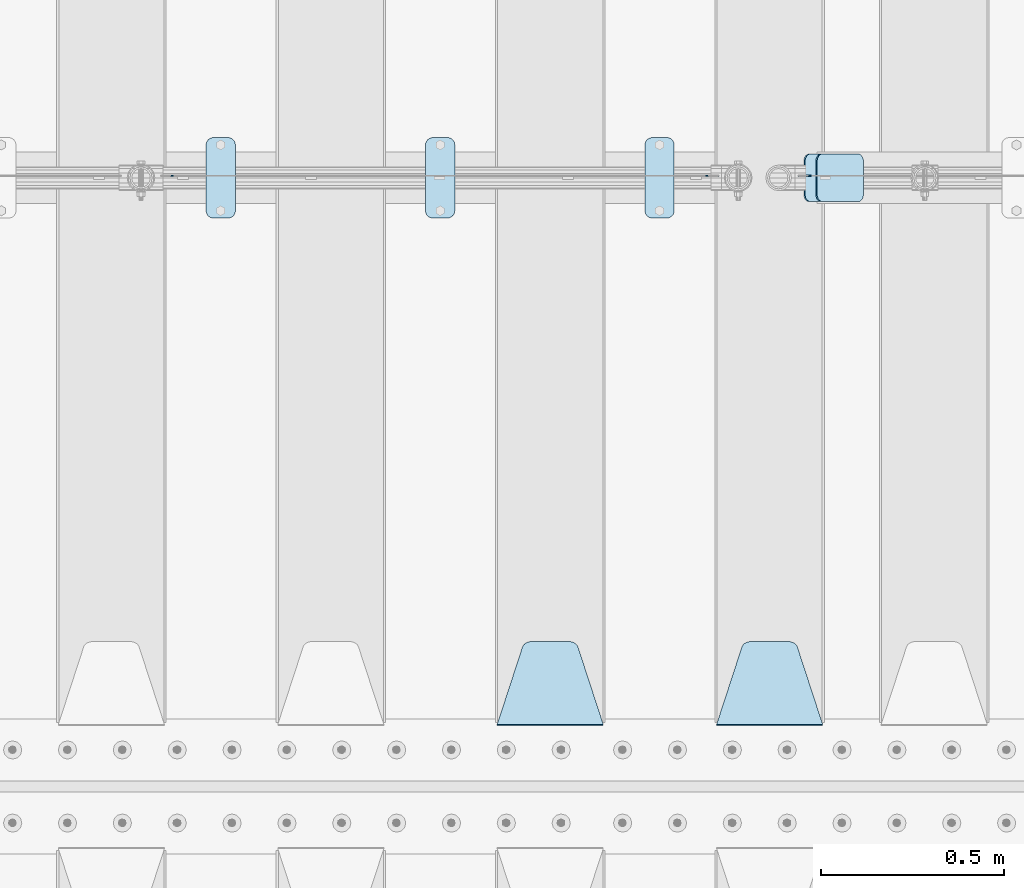
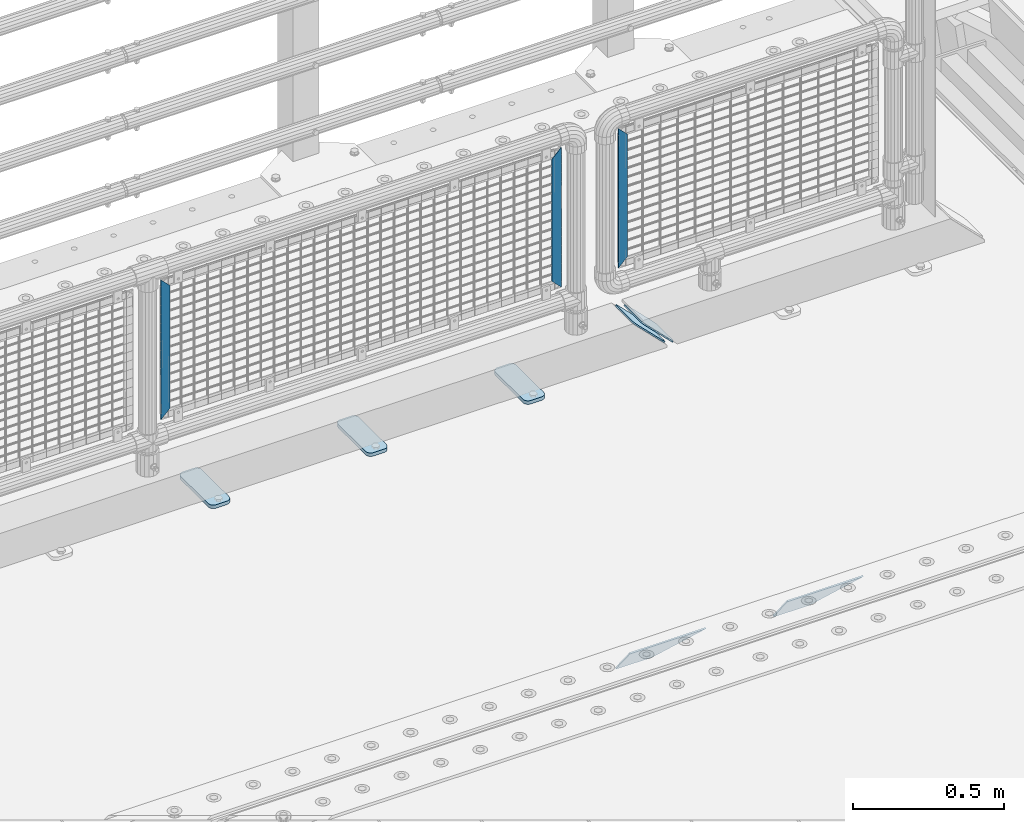
# One storey, part 223 of 242: 10 plates.
"""IFC2X3 building model written with IfcOpenShell, lengths in millimetres."""

import ifcopenshell
import ifcopenshell.guid

model = None  # the IFC model being written
_history = None  # IfcOwnerHistory: only IFC2X3 demands one
_inside = {}  # id of a spatial element -> (the spatial element, [elements in it])
_under = {}  # id of a project, library or spatial element -> (it, [spatial elements below it])
_declared = {}  # id of a project -> (the project, [libraries it declares])
_typed = {}  # id of a type object -> (the type object, [elements of that type])
_made_of = {}  # id of a material, layer set ... -> (it, [elements and type objects made of it])


def new_model(schema):
    """Start an empty IFC model of exactly this schema.

    Asked for "IFC4X3", IfcOpenShell would pick the latest addendum, in which some entities
    have other attributes; the version numbers below select the first issue.
    IFC2X3 requires an IfcOwnerHistory on every rooted entity: one is made here for all.
    """
    global model, _history
    if schema == "IFC4X3":
        model = ifcopenshell.file(schema_version=(4, 3, 0, 0))
    else:
        model = ifcopenshell.file(schema=schema)
    _inside.clear()
    _under.clear()
    _declared.clear()
    _typed.clear()
    _made_of.clear()
    _history = None
    if model.schema == "IFC2X3":
        org = make("IfcOrganization", Name="unknown")
        user = make(
            "IfcPersonAndOrganization",
            ThePerson=make("IfcPerson", FamilyName="unknown"),
            TheOrganization=org,
        )
        app = make(
            "IfcApplication",
            ApplicationDeveloper=org,
            Version="unknown",
            ApplicationFullName="unknown",
            ApplicationIdentifier="unknown",
        )
        _history = make(
            "IfcOwnerHistory",
            OwningUser=user,
            OwningApplication=app,
            ChangeAction="ADDED",
            CreationDate=0,
        )
    return model


def make(cls, **values):
    """One entity of the class cls with the attributes given. An attribute that is None is left unset."""
    return model.create_entity(
        cls, **{name: value for name, value in values.items() if value is not None}
    )


def rooted(cls, **values):
    """An entity with a GlobalId (a new one), such as an element, a storey or a relation."""
    return make(cls, GlobalId=ifcopenshell.guid.new(), OwnerHistory=_history, **values)


def si_unit(unit_type, name, prefix=None):
    """IfcSIUnit, for example si_unit("LENGTHUNIT", "METRE", prefix="MILLI")."""
    return make("IfcSIUnit", UnitType=unit_type, Prefix=prefix, Name=name)


def assignment(units):
    """IfcUnitAssignment: the units of a project."""
    return None if units is None else make("IfcUnitAssignment", Units=units)


def point(xyz):
    """IfcCartesianPoint."""
    return None if xyz is None else make("IfcCartesianPoint", Coordinates=xyz)


def direction(xyz):
    """IfcDirection."""
    return None if xyz is None else make("IfcDirection", DirectionRatios=xyz)


def frame(location, z_axis=None, x_axis=None):
    """IfcAxis2Placement3D, a coordinate frame: its origin and axes. An axis left out is left unset."""
    return make(
        "IfcAxis2Placement3D",
        Location=point(location),
        Axis=direction(z_axis),
        RefDirection=direction(x_axis),
    )


def origin_with_axes():
    """The frame at (0, 0, 0) with the z axis (0, 0, 1) and the x axis (1, 0, 0) written out."""
    return frame((0.0, 0.0, 0.0), z_axis=(0.0, 0.0, 1.0), x_axis=(1.0, 0.0, 0.0))


def place(relative_to, where):
    """IfcLocalPlacement: puts the frame where relative to a parent placement (None: the world)."""
    return make(
        "IfcLocalPlacement", PlacementRelTo=relative_to, RelativePlacement=where
    )


def context(
    kind, dimensions, precision=None, world=None, true_north=None, identifier=None
):
    """IfcGeometricRepresentationContext, for example the 3D "Model" context."""
    return make(
        "IfcGeometricRepresentationContext",
        ContextIdentifier=identifier,
        ContextType=kind,
        CoordinateSpaceDimension=dimensions,
        Precision=precision,
        WorldCoordinateSystem=world,
        TrueNorth=true_north,
    )


def subcontext(parent, identifier, kind, view, scale=None):
    """IfcGeometricRepresentationSubContext, for example "Body" below "Model"."""
    return make(
        "IfcGeometricRepresentationSubContext",
        ContextIdentifier=identifier,
        ContextType=kind,
        ParentContext=parent,
        TargetScale=scale,
        TargetView=view,
    )


def project(units=None, contexts=None):
    """IfcProject with its units and contexts."""
    return rooted(
        "IfcProject",
        Name="project",
        RepresentationContexts=contexts,
        UnitsInContext=assignment(units),
    )


def spatial(cls, under=None, at=None, **own):
    """A site, building, storey or space (cls), placed at a placement, below another one or the project."""
    s = rooted(cls, ObjectPlacement=at, **own)
    if under is not None:
        _under.setdefault(under.id(), (under, []))[1].append(s)
    return s


def faces_of(points, faces, orient=None, outer=None):
    """IfcFace entities. A face is a list of loops; a loop is a list of indices into points, from 0.

    orient and outer hold one flag for each loop. By default every Orientation is true, the
    first loop of a face is its IfcFaceOuterBound and the others are IfcFaceBound.
    """
    made = []
    for i, loops in enumerate(faces):
        bounds = []
        for j, loop in enumerate(loops):
            is_outer = j == 0 if outer is None else outer[i][j]
            bounds.append(
                make(
                    "IfcFaceOuterBound" if is_outer else "IfcFaceBound",
                    Bound=make("IfcPolyLoop", Polygon=[points[k] for k in loop]),
                    Orientation=True if orient is None else orient[i][j],
                )
            )
        made.append(make("IfcFace", Bounds=bounds))
    return made


def faceted_brep(points, faces, orient=None, outer=None, voids=None):
    """IfcFacetedBrep: a solid bounded by flat faces; with voids (closed shells), ...WithVoids."""
    shared = [point(p) for p in points]
    hull = make("IfcClosedShell", CfsFaces=faces_of(shared, faces, orient, outer))
    if voids is None:
        return make("IfcFacetedBrep", Outer=hull)
    return make(
        "IfcFacetedBrepWithVoids",
        Outer=hull,
        Voids=[
            make(cls, CfsFaces=faces_of(shared, fs, o, b)) for cls, fs, o, b in voids
        ],
    )


def shape(context_of_items, identifier, shape_type, items):
    """IfcShapeRepresentation: the items that make up one representation, for example the "Body"."""
    return make(
        "IfcShapeRepresentation",
        ContextOfItems=context_of_items,
        RepresentationIdentifier=identifier,
        RepresentationType=shape_type,
        Items=items,
    )


def material(Name=None, Category=None):
    """IfcMaterial."""
    return make("IfcMaterial", Name=Name, Category=Category)


def made_of(thing, what):
    """Note that an element or type object is made of a material, layer set ...; save() writes the relation."""
    if what is not None:
        _made_of.setdefault(what.id(), (what, []))[1].append(thing)
    return thing


def type_object(cls, material=None, **own):
    """A type object (cls), such as IfcWallType, which elements share."""
    return made_of(rooted(cls, **own), material)


def element(
    cls,
    number,
    at=None,
    inside=None,
    cuts=None,
    type_object=None,
    material=None,
    context=None,
    identifier="Body",
    shape_type=None,
    held_by="IfcProductDefinitionShape",
    body=None,
    shapes=None,
    **own,
):
    """One element of the class cls, such as IfcWall. Its Tag is "e" and its number.

    at: its placement. inside: the storey or other place that contains it. cuts: it is an
    opening in that element (IfcRelVoidsElement). A single representation is given by context,
    identifier, shape_type and body (its items); several are given by shapes. held_by: the class
    of the entity that holds the representations. save() writes the other relations.
    """
    e = rooted(cls, Tag="e%d" % number, ObjectPlacement=at, **own)
    if body is not None:
        shapes = [shape(context, identifier, shape_type, body)]
    if shapes is not None:
        e.Representation = make(held_by, Representations=shapes)
    if inside is not None:
        _inside.setdefault(inside.id(), (inside, []))[1].append(e)
    if cuts is not None:
        rooted(
            "IfcRelVoidsElement", RelatingBuildingElement=cuts, RelatedOpeningElement=e
        )
    if type_object is not None:
        _typed.setdefault(type_object.id(), (type_object, []))[1].append(e)
    return made_of(e, material)


def aggregate(whole, parts):
    """IfcRelAggregates: a whole, such as a stair, and the parts it consists of."""
    return rooted("IfcRelAggregates", RelatingObject=whole, RelatedObjects=parts)


def save(model, path):
    """Write the relations noted so far, then the file.

    IfcRelAggregates (storeys below a building ...), IfcRelContainedInSpatialStructure (elements
    in a storey), IfcRelDefinesByType, IfcRelAssociatesMaterial and IfcRelDeclares: one each for
    every whole, place, type object, material and project.
    """
    for whole, parts in _under.values():
        aggregate(whole, parts)
    for where, things in _inside.values():
        rooted(
            "IfcRelContainedInSpatialStructure",
            RelatedElements=things,
            RelatingStructure=where,
        )
    for kind, things in _typed.values():
        rooted("IfcRelDefinesByType", RelatedObjects=things, RelatingType=kind)
    for what, things in _made_of.values():
        rooted("IfcRelAssociatesMaterial", RelatedObjects=things, RelatingMaterial=what)
    for by, libraries in _declared.values():
        rooted("IfcRelDeclares", RelatingContext=by, RelatedDefinitions=libraries)
    model.write(path)


model = new_model("IFC2X3")

# Units and contexts
model_context = context("Model", 3, precision=1e-05, world=origin_with_axes())
body_context = subcontext(model_context, "Body", "Model", "MODEL_VIEW")
ifc_project = project(units=[si_unit("LENGTHUNIT", "METRE", prefix="MILLI"), si_unit("AREAUNIT", "SQUARE_METRE"), si_unit("VOLUMEUNIT", "CUBIC_METRE"), si_unit("MASSUNIT", "GRAM", prefix="KILO"), si_unit("TIMEUNIT", "SECOND"), si_unit("PLANEANGLEUNIT", "RADIAN"), si_unit("SOLIDANGLEUNIT", "STERADIAN"), si_unit("THERMODYNAMICTEMPERATUREUNIT", "DEGREE_CELSIUS"), si_unit("LUMINOUSINTENSITYUNIT", "LUMEN")], contexts=[model_context])

# Site, building, storey
site_placement = place(None, origin_with_axes())
site = spatial("IfcSite", under=ifc_project, at=site_placement, CompositionType="ELEMENT")
building_placement = place(site_placement, origin_with_axes())
building = spatial("IfcBuilding", under=site, at=building_placement, Name="Standard", CompositionType="ELEMENT")
storey_placement = place(building_placement, origin_with_axes())
storey = spatial("IfcBuildingStorey", under=building, at=storey_placement, Name="Undefined", CompositionType="ELEMENT", Elevation=0.0)

# Plates
ifc_material_1 = material(Name="Misc_Undefined")
plate_type_1 = type_object("IfcPlateType", PredefinedType="NOTDEFINED")
plate_1_placement = place(storey_placement, frame((-23666.8899741176, -19329.5000354956, 879.520017263589), z_axis=(-0.707106781186548, 0.0, -0.707106781186548), x_axis=(-0.707106781186548, 0.0, 0.707106781186548)))
element("IfcPlate", 1, at=plate_1_placement, inside=storey, type_object=plate_type_1, material=ifc_material_1, context=body_context, shape_type="Brep", body=[
    faceted_brep([(0.0, -1.50000000000364, 0.0), (-348.603637695367, -1.50000000000364, 348.603668212891), (-348.603637695367, 1.5, 348.603668212887), (-3.63797880709171e-12, 1.49999999999636, 0.0), (-348.603637695374, -1.50000000000364, 398.101165771481), (-348.603637695378, 1.5, 398.101165771481), (49.4974975585974, -1.50000000000364, 1.63709046319127e-11), (49.4974975585938, 1.49999999999636, 1.81898940354586e-11)], [[[0, 1, 2, 3]], [[1, 4, 5, 2]], [[4, 6, 7, 5]], [[6, 0, 3, 7]], [[5, 7, 3, 2]], [[6, 4, 1, 0]]]),
])
plate_2_placement = place(storey_placement, frame((-25410.490286459, -19329.5, 879.519963133601), z_axis=(-0.707008801899319, 0.0, -0.707204746899291), x_axis=(-0.707204746899296, 0.0, 0.707008801899313)))
element("IfcPlate", 2, at=plate_2_placement, inside=storey, type_object=plate_type_1, material=ifc_material_1, context=body_context, shape_type="Brep", body=[
    faceted_brep([(0.0, -1.50000000000364, 0.0), (-348.552185058597, -1.5, 348.655029296875), (-348.552185058597, 1.5, 348.655029296875), (-3.63797880709171e-12, 1.49999999999636, 0.0), (-348.544891357426, -1.5, 398.152496337891), (-348.544891357426, 1.5, 398.152496337891), (49.5043945312464, -1.5, 8.00355337560177e-11), (49.5043945312464, 1.5, 8.00355337560177e-11)], [[[0, 1, 2, 3]], [[1, 4, 5, 2]], [[4, 6, 7, 5]], [[6, 0, 3, 7]], [[5, 7, 3, 2]], [[6, 4, 1, 0]]]),
])
plate_3_placement = place(storey_placement, frame((-23954.5003125164, -19329.5, 879.52), z_axis=(0.707103624179499, 0.0, -0.707109938179501), x_axis=(0.707109938179508, 0.0, 0.707103624179492)))
element("IfcPlate", 3, at=plate_3_placement, inside=storey, type_object=plate_type_1, material=ifc_material_1, context=body_context, shape_type="Brep", body=[
    faceted_brep([(0.0, -1.50000000000364, 0.0), (-348.605163574222, -1.5, 348.602081298832), (-348.605163574222, 1.5, 348.602081298832), (-3.63797880709171e-12, 1.49999999999636, 0.0), (-348.605163574222, -1.5, 398.099334716801), (-348.605163574222, 1.5, 398.099334716801), (49.4976959228534, -1.5, -3.63797880709171e-12), (49.4976959228534, 1.5, -3.63797880709171e-12)], [[[0, 1, 2, 3]], [[1, 4, 5, 2]], [[4, 6, 7, 5]], [[6, 0, 3, 7]], [[5, 7, 3, 2]], [[6, 4, 1, 0]]]),
])
ifc_material_2 = material(Name="STEEL/S355J2")
plate_type_2 = type_object("IfcPlateType", PredefinedType="NOTDEFINED")
plate_4_placement = place(storey_placement, frame((-24121.0, -19225.5, 21.0199999999977), z_axis=(1.0, 0.0, 0.0), x_axis=(0.0, -1.0, 0.0)))
element("IfcPlate", 4, at=plate_4_placement, inside=storey, type_object=plate_type_2, material=ifc_material_2, context=body_context, shape_type="Brep", body=[
    faceted_brep([(0.0, -7.0, 20.0), (0.0, -7.0, 60.0), (0.0, 7.0, 60.0), (0.0, 7.0, 20.0), (0.384294391937146, -7.0, 63.9018064403208), (0.384294391937146, 7.0, 63.9018064403208), (1.52240934977453, -7.0, 67.6536686473009), (1.52240934977453, 7.0, 67.6536686473009), (3.37060775395003, -7.0, 71.1114046603907), (3.37060775395003, 7.0, 71.1114046603907), (5.8578643762703, -7.0, 74.1421356237297), (5.8578643762703, 7.0, 74.1421356237297), (8.88859533960931, -7.0, 76.62939224605), (8.88859533960931, 7.0, 76.62939224605), (12.3463313526991, -7.0, 78.4775906502255), (12.3463313526991, 7.0, 78.4775906502255), (16.0981935596792, -7.0, 79.6157056080629), (16.0981935596792, 7.0, 79.6157056080629), (20.0, -7.0, 80.0), (20.0, 7.0, 80.0), (200.0, -7.0, 80.0), (200.0, 7.0, 80.0), (203.901806440321, -7.0, 79.6157056080629), (203.901806440321, 7.0, 79.6157056080629), (207.653668647301, -7.0, 78.4775906502255), (207.653668647301, 7.0, 78.4775906502255), (211.111404660391, -7.0, 76.62939224605), (211.111404660391, 7.0, 76.62939224605), (214.14213562373, -7.0, 74.1421356237297), (214.14213562373, 7.0, 74.1421356237297), (216.62939224605, -7.0, 71.1114046603907), (216.62939224605, 7.0, 71.1114046603907), (218.477590650225, -7.0, 67.6536686473009), (218.477590650225, 7.0, 67.6536686473009), (219.615705608063, -7.0, 63.9018064403208), (219.615705608063, 7.0, 63.9018064403208), (220.0, -7.0, 60.0), (220.0, 7.0, 60.0), (220.0, -7.0, 20.0), (220.0, 7.0, 20.0), (219.615705608063, -7.0, 16.0981935596792), (219.615705608063, 7.0, 16.0981935596792), (218.477590650225, -7.0, 12.3463313526991), (218.477590650225, 7.0, 12.3463313526991), (216.62939224605, -7.0, 8.88859533960931), (216.62939224605, 7.0, 8.88859533960931), (214.14213562373, -7.0, 5.8578643762703), (214.14213562373, 7.0, 5.8578643762703), (211.111404660391, -7.0, 3.37060775395003), (211.111404660391, 7.0, 3.37060775395003), (207.653668647301, -7.0, 1.52240934977453), (207.653668647301, 7.0, 1.52240934977453), (203.901806440321, -7.0, 0.384294391937146), (203.901806440321, 7.0, 0.384294391937146), (200.0, -7.0, 0.0), (200.0, 7.0, 0.0), (20.0, -7.0, 0.0), (20.0, 7.0, 0.0), (16.0981935596792, -7.0, 0.384294391937146), (16.0981935596792, 7.0, 0.384294391937146), (12.3463313526991, -7.0, 1.52240934977453), (12.3463313526991, 7.0, 1.52240934977453), (8.88859533960931, -7.0, 3.37060775395003), (8.88859533960931, 7.0, 3.37060775395003), (5.8578643762703, -7.0, 5.8578643762703), (5.8578643762703, 7.0, 5.8578643762703), (3.37060775395003, -7.0, 8.88859533960931), (3.37060775395003, 7.0, 8.88859533960931), (1.52240934977453, -7.0, 12.3463313526991), (1.52240934977453, 7.0, 12.3463313526991), (0.384294391937146, -7.0, 16.0981935596792), (0.384294391937146, 7.0, 16.0981935596792)], [[[0, 1, 2, 3]], [[1, 4, 5, 2]], [[4, 6, 7, 5]], [[6, 8, 9, 7]], [[8, 10, 11, 9]], [[10, 12, 13, 11]], [[12, 14, 15, 13]], [[14, 16, 17, 15]], [[16, 18, 19, 17]], [[18, 20, 21, 19]], [[20, 22, 23, 21]], [[22, 24, 25, 23]], [[24, 26, 27, 25]], [[26, 28, 29, 27]], [[28, 30, 31, 29]], [[30, 32, 33, 31]], [[32, 34, 35, 33]], [[34, 36, 37, 35]], [[36, 38, 39, 37]], [[38, 40, 41, 39]], [[40, 42, 43, 41]], [[42, 44, 45, 43]], [[44, 46, 47, 45]], [[46, 48, 49, 47]], [[48, 50, 51, 49]], [[50, 52, 53, 51]], [[52, 54, 55, 53]], [[54, 56, 57, 55]], [[56, 58, 59, 57]], [[58, 60, 61, 59]], [[60, 62, 63, 61]], [[62, 64, 65, 63]], [[64, 66, 67, 65]], [[66, 68, 69, 67]], [[68, 70, 71, 69]], [[70, 0, 3, 71]], [[5, 7, 9, 11, 13, 15, 17, 19, 21, 23, 25, 27, 29, 31, 33, 35, 37, 39, 41, 43, 45, 47, 49, 51, 53, 55, 57, 59, 61, 63, 65, 67, 69, 71, 3, 2]], [[70, 68, 66, 64, 62, 60, 58, 56, 54, 52, 50, 48, 46, 44, 42, 40, 38, 36, 34, 32, 30, 28, 26, 24, 22, 20, 18, 16, 14, 12, 10, 8, 6, 4, 1, 0]]]),
])
plate_5_placement = place(storey_placement, frame((-24721.0, -19225.5, 21.0199999999977), z_axis=(1.0, 0.0, 0.0), x_axis=(0.0, -1.0, 0.0)))
element("IfcPlate", 5, at=plate_5_placement, inside=storey, type_object=plate_type_2, material=ifc_material_2, context=body_context, shape_type="Brep", body=[
    faceted_brep([(0.0, -7.0, 20.0), (0.0, -7.0, 60.0), (0.0, 7.0, 60.0), (0.0, 7.0, 20.0), (0.384294391937146, -7.0, 63.9018064403208), (0.384294391937146, 7.0, 63.9018064403208), (1.52240934977453, -7.0, 67.6536686473009), (1.52240934977453, 7.0, 67.6536686473009), (3.37060775395003, -7.0, 71.1114046603907), (3.37060775395003, 7.0, 71.1114046603907), (5.8578643762703, -7.0, 74.1421356237297), (5.8578643762703, 7.0, 74.1421356237297), (8.88859533960931, -7.0, 76.62939224605), (8.88859533960931, 7.0, 76.62939224605), (12.3463313526991, -7.0, 78.4775906502255), (12.3463313526991, 7.0, 78.4775906502255), (16.0981935596792, -7.0, 79.6157056080629), (16.0981935596792, 7.0, 79.6157056080629), (20.0, -7.0, 80.0), (20.0, 7.0, 80.0), (200.0, -7.0, 80.0), (200.0, 7.0, 80.0), (203.901806440321, -7.0, 79.6157056080629), (203.901806440321, 7.0, 79.6157056080629), (207.653668647301, -7.0, 78.4775906502255), (207.653668647301, 7.0, 78.4775906502255), (211.111404660391, -7.0, 76.62939224605), (211.111404660391, 7.0, 76.62939224605), (214.14213562373, -7.0, 74.1421356237297), (214.14213562373, 7.0, 74.1421356237297), (216.62939224605, -7.0, 71.1114046603907), (216.62939224605, 7.0, 71.1114046603907), (218.477590650225, -7.0, 67.6536686473009), (218.477590650225, 7.0, 67.6536686473009), (219.615705608063, -7.0, 63.9018064403208), (219.615705608063, 7.0, 63.9018064403208), (220.0, -7.0, 60.0), (220.0, 7.0, 60.0), (220.0, -7.0, 20.0), (220.0, 7.0, 20.0), (219.615705608063, -7.0, 16.0981935596792), (219.615705608063, 7.0, 16.0981935596792), (218.477590650225, -7.0, 12.3463313526991), (218.477590650225, 7.0, 12.3463313526991), (216.62939224605, -7.0, 8.88859533960931), (216.62939224605, 7.0, 8.88859533960931), (214.14213562373, -7.0, 5.8578643762703), (214.14213562373, 7.0, 5.8578643762703), (211.111404660391, -7.0, 3.37060775395003), (211.111404660391, 7.0, 3.37060775395003), (207.653668647301, -7.0, 1.52240934977453), (207.653668647301, 7.0, 1.52240934977453), (203.901806440321, -7.0, 0.384294391937146), (203.901806440321, 7.0, 0.384294391937146), (200.0, -7.0, 0.0), (200.0, 7.0, 0.0), (20.0, -7.0, 0.0), (20.0, 7.0, 0.0), (16.0981935596792, -7.0, 0.384294391937146), (16.0981935596792, 7.0, 0.384294391937146), (12.3463313526991, -7.0, 1.52240934977453), (12.3463313526991, 7.0, 1.52240934977453), (8.88859533960931, -7.0, 3.37060775395003), (8.88859533960931, 7.0, 3.37060775395003), (5.8578643762703, -7.0, 5.8578643762703), (5.8578643762703, 7.0, 5.8578643762703), (3.37060775395003, -7.0, 8.88859533960931), (3.37060775395003, 7.0, 8.88859533960931), (1.52240934977453, -7.0, 12.3463313526991), (1.52240934977453, 7.0, 12.3463313526991), (0.384294391937146, -7.0, 16.0981935596792), (0.384294391937146, 7.0, 16.0981935596792)], [[[0, 1, 2, 3]], [[1, 4, 5, 2]], [[4, 6, 7, 5]], [[6, 8, 9, 7]], [[8, 10, 11, 9]], [[10, 12, 13, 11]], [[12, 14, 15, 13]], [[14, 16, 17, 15]], [[16, 18, 19, 17]], [[18, 20, 21, 19]], [[20, 22, 23, 21]], [[22, 24, 25, 23]], [[24, 26, 27, 25]], [[26, 28, 29, 27]], [[28, 30, 31, 29]], [[30, 32, 33, 31]], [[32, 34, 35, 33]], [[34, 36, 37, 35]], [[36, 38, 39, 37]], [[38, 40, 41, 39]], [[40, 42, 43, 41]], [[42, 44, 45, 43]], [[44, 46, 47, 45]], [[46, 48, 49, 47]], [[48, 50, 51, 49]], [[50, 52, 53, 51]], [[52, 54, 55, 53]], [[54, 56, 57, 55]], [[56, 58, 59, 57]], [[58, 60, 61, 59]], [[60, 62, 63, 61]], [[62, 64, 65, 63]], [[64, 66, 67, 65]], [[66, 68, 69, 67]], [[68, 70, 71, 69]], [[70, 0, 3, 71]], [[5, 7, 9, 11, 13, 15, 17, 19, 21, 23, 25, 27, 29, 31, 33, 35, 37, 39, 41, 43, 45, 47, 49, 51, 53, 55, 57, 59, 61, 63, 65, 67, 69, 71, 3, 2]], [[70, 68, 66, 64, 62, 60, 58, 56, 54, 52, 50, 48, 46, 44, 42, 40, 38, 36, 34, 32, 30, 28, 26, 24, 22, 20, 18, 16, 14, 12, 10, 8, 6, 4, 1, 0]]]),
])
plate_6_placement = place(storey_placement, frame((-25321.0, -19225.5, 21.0199999999977), z_axis=(1.0, 0.0, 0.0), x_axis=(0.0, -1.0, 0.0)))
element("IfcPlate", 6, at=plate_6_placement, inside=storey, type_object=plate_type_2, material=ifc_material_2, context=body_context, shape_type="Brep", body=[
    faceted_brep([(0.0, -7.0, 20.0), (0.0, -7.0, 60.0), (0.0, 7.0, 60.0), (0.0, 7.0, 20.0), (0.384294391937146, -7.0, 63.9018064403208), (0.384294391937146, 7.0, 63.9018064403208), (1.52240934977453, -7.0, 67.6536686473009), (1.52240934977453, 7.0, 67.6536686473009), (3.37060775395003, -7.0, 71.1114046603907), (3.37060775395003, 7.0, 71.1114046603907), (5.8578643762703, -7.0, 74.1421356237297), (5.8578643762703, 7.0, 74.1421356237297), (8.88859533960931, -7.0, 76.62939224605), (8.88859533960931, 7.0, 76.62939224605), (12.3463313526991, -7.0, 78.4775906502255), (12.3463313526991, 7.0, 78.4775906502255), (16.0981935596792, -7.0, 79.6157056080629), (16.0981935596792, 7.0, 79.6157056080629), (20.0, -7.0, 80.0), (20.0, 7.0, 80.0), (200.0, -7.0, 80.0), (200.0, 7.0, 80.0), (203.901806440321, -7.0, 79.6157056080629), (203.901806440321, 7.0, 79.6157056080629), (207.653668647301, -7.0, 78.4775906502255), (207.653668647301, 7.0, 78.4775906502255), (211.111404660391, -7.0, 76.62939224605), (211.111404660391, 7.0, 76.62939224605), (214.14213562373, -7.0, 74.1421356237297), (214.14213562373, 7.0, 74.1421356237297), (216.62939224605, -7.0, 71.1114046603907), (216.62939224605, 7.0, 71.1114046603907), (218.477590650225, -7.0, 67.6536686473009), (218.477590650225, 7.0, 67.6536686473009), (219.615705608063, -7.0, 63.9018064403208), (219.615705608063, 7.0, 63.9018064403208), (220.0, -7.0, 60.0), (220.0, 7.0, 60.0), (220.0, -7.0, 20.0), (220.0, 7.0, 20.0), (219.615705608063, -7.0, 16.0981935596792), (219.615705608063, 7.0, 16.0981935596792), (218.477590650225, -7.0, 12.3463313526991), (218.477590650225, 7.0, 12.3463313526991), (216.62939224605, -7.0, 8.88859533960931), (216.62939224605, 7.0, 8.88859533960931), (214.14213562373, -7.0, 5.8578643762703), (214.14213562373, 7.0, 5.8578643762703), (211.111404660391, -7.0, 3.37060775395003), (211.111404660391, 7.0, 3.37060775395003), (207.653668647301, -7.0, 1.52240934977453), (207.653668647301, 7.0, 1.52240934977453), (203.901806440321, -7.0, 0.384294391937146), (203.901806440321, 7.0, 0.384294391937146), (200.0, -7.0, 0.0), (200.0, 7.0, 0.0), (20.0, -7.0, 0.0), (20.0, 7.0, 0.0), (16.0981935596792, -7.0, 0.384294391937146), (16.0981935596792, 7.0, 0.384294391937146), (12.3463313526991, -7.0, 1.52240934977453), (12.3463313526991, 7.0, 1.52240934977453), (8.88859533960931, -7.0, 3.37060775395003), (8.88859533960931, 7.0, 3.37060775395003), (5.8578643762703, -7.0, 5.8578643762703), (5.8578643762703, 7.0, 5.8578643762703), (3.37060775395003, -7.0, 8.88859533960931), (3.37060775395003, 7.0, 8.88859533960931), (1.52240934977453, -7.0, 12.3463313526991), (1.52240934977453, 7.0, 12.3463313526991), (0.384294391937146, -7.0, 16.0981935596792), (0.384294391937146, 7.0, 16.0981935596792)], [[[0, 1, 2, 3]], [[1, 4, 5, 2]], [[4, 6, 7, 5]], [[6, 8, 9, 7]], [[8, 10, 11, 9]], [[10, 12, 13, 11]], [[12, 14, 15, 13]], [[14, 16, 17, 15]], [[16, 18, 19, 17]], [[18, 20, 21, 19]], [[20, 22, 23, 21]], [[22, 24, 25, 23]], [[24, 26, 27, 25]], [[26, 28, 29, 27]], [[28, 30, 31, 29]], [[30, 32, 33, 31]], [[32, 34, 35, 33]], [[34, 36, 37, 35]], [[36, 38, 39, 37]], [[38, 40, 41, 39]], [[40, 42, 43, 41]], [[42, 44, 45, 43]], [[44, 46, 47, 45]], [[46, 48, 49, 47]], [[48, 50, 51, 49]], [[50, 52, 53, 51]], [[52, 54, 55, 53]], [[54, 56, 57, 55]], [[56, 58, 59, 57]], [[58, 60, 61, 59]], [[60, 62, 63, 61]], [[62, 64, 65, 63]], [[64, 66, 67, 65]], [[66, 68, 69, 67]], [[68, 70, 71, 69]], [[70, 0, 3, 71]], [[5, 7, 9, 11, 13, 15, 17, 19, 21, 23, 25, 27, 29, 31, 33, 35, 37, 39, 41, 43, 45, 47, 49, 51, 53, 55, 57, 59, 61, 63, 65, 67, 69, 71, 3, 2]], [[70, 68, 66, 64, 62, 60, 58, 56, 54, 52, 50, 48, 46, 44, 42, 40, 38, 36, 34, 32, 30, 28, 26, 24, 22, 20, 18, 16, 14, 12, 10, 8, 6, 4, 1, 0]]]),
])
plate_type_3 = type_object("IfcPlateType", PredefinedType="NOTDEFINED")
plate_7_placement = place(storey_placement, frame((-23684.807581521, -19270.5, 166.254400376567), z_axis=(0.707410512925777, 0.0, -0.706802918925841), x_axis=(0.0, -1.0, 0.0)))
element("IfcPlate", 7, at=plate_7_placement, inside=storey, type_object=plate_type_3, material=ifc_material_2, context=body_context, shape_type="Brep", body=[
    faceted_brep([(0.0, -2.49999999999636, 20.0), (0.0, -2.49999999999636, 158.926651000977), (0.0, 2.50000000000364, 158.926651000977), (0.0, 2.50000000000364, 20.0), (0.384294391937146, -2.49999999999636, 162.828457441301), (0.384294391937146, 2.50000000000364, 162.828457441301), (1.52240934977453, -2.49999999999636, 166.580319648281), (1.52240934977453, 2.50000000000364, 166.580319648281), (3.37060775395003, -2.49999999999636, 170.038055661371), (3.37060775395003, 2.50000000000364, 170.038055661371), (5.8578643762703, -2.49999999999636, 173.068786624706), (5.8578643762703, 2.50000000000364, 173.06878662471), (8.88859533960931, -2.5, 175.55604324703), (8.88859533960931, 2.50000000000364, 175.55604324703), (12.3463313526991, -2.49999999999636, 177.404241651206), (12.3463313526991, 2.50000000000364, 177.404241651206), (16.0981935596792, -2.49999999999636, 178.542356609043), (16.0981935596792, 2.50000000000728, 178.542356609043), (20.0, -2.49999999999272, 178.926651000977), (20.0, 2.50000000000364, 178.92665100098), (110.0, -2.49999999999272, 178.926651000977), (110.0, 2.50000000000364, 178.92665100098), (113.901806440321, -2.49999999999636, 178.542356609043), (113.901806440321, 2.50000000000728, 178.542356609043), (117.653668647301, -2.49999999999636, 177.404241651206), (117.653668647301, 2.50000000000364, 177.404241651206), (121.111404660391, -2.5, 175.55604324703), (121.111404660391, 2.50000000000364, 175.55604324703), (124.14213562373, -2.49999999999636, 173.068786624706), (124.14213562373, 2.50000000000364, 173.06878662471), (126.62939224605, -2.49999999999636, 170.038055661371), (126.62939224605, 2.50000000000364, 170.038055661371), (128.477590650225, -2.49999999999636, 166.580319648281), (128.477590650225, 2.50000000000364, 166.580319648281), (129.615705608063, -2.49999999999636, 162.828457441301), (129.615705608063, 2.50000000000364, 162.828457441301), (130.0, -2.49999999999636, 158.926651000977), (130.0, 2.50000000000364, 158.926651000977), (130.0, -2.49999999999636, 20.0), (130.0, 2.50000000000364, 20.0), (129.615705608063, -2.49999999999636, 16.0981935596792), (129.615705608063, 2.50000000000364, 16.0981935596792), (128.477590650225, -2.49999999999636, 12.3463313526991), (128.477590650225, 2.50000000000364, 12.3463313526991), (126.62939224605, -2.49999999999636, 8.88859533961295), (126.62939224605, 2.5, 8.88859533960931), (124.14213562373, -2.49999999999636, 5.8578643762703), (124.14213562373, 2.5, 5.8578643762703), (121.111404660391, -2.49999999999636, 3.37060775395003), (121.111404660391, 2.50000000000364, 3.37060775395003), (117.653668647301, -2.49999999999636, 1.52240934977453), (117.653668647301, 2.50000000000364, 1.52240934977453), (113.901806440321, -2.49999999999636, 0.384294391933508), (113.901806440321, 2.50000000000364, 0.384294391937146), (110.0, -2.49999999999636, 3.63797880709171e-12), (110.0, 2.50000000000728, 3.63797880709171e-12), (20.0, -2.49999999999636, 3.63797880709171e-12), (20.0, 2.50000000000728, 3.63797880709171e-12), (16.0981935596792, -2.49999999999636, 0.384294391933508), (16.0981935596792, 2.50000000000364, 0.384294391937146), (12.3463313526991, -2.49999999999636, 1.52240934977453), (12.3463313526991, 2.50000000000364, 1.52240934977453), (8.88859533960931, -2.49999999999636, 3.37060775395003), (8.88859533960931, 2.50000000000364, 3.37060775395003), (5.8578643762703, -2.49999999999636, 5.8578643762703), (5.8578643762703, 2.5, 5.8578643762703), (3.37060775395003, -2.49999999999636, 8.88859533961295), (3.37060775395003, 2.5, 8.88859533960931), (1.52240934977453, -2.49999999999636, 12.3463313526991), (1.52240934977453, 2.50000000000364, 12.3463313526991), (0.384294391937146, -2.49999999999636, 16.0981935596792), (0.384294391937146, 2.50000000000364, 16.0981935596792)], [[[0, 1, 2, 3]], [[1, 4, 5, 2]], [[4, 6, 7, 5]], [[6, 8, 9, 7]], [[8, 10, 11, 9]], [[10, 12, 13, 11]], [[12, 14, 15, 13]], [[14, 16, 17, 15]], [[16, 18, 19, 17]], [[18, 20, 21, 19]], [[20, 22, 23, 21]], [[22, 24, 25, 23]], [[24, 26, 27, 25]], [[26, 28, 29, 27]], [[28, 30, 31, 29]], [[30, 32, 33, 31]], [[32, 34, 35, 33]], [[34, 36, 37, 35]], [[36, 38, 39, 37]], [[38, 40, 41, 39]], [[40, 42, 43, 41]], [[42, 44, 45, 43]], [[44, 46, 47, 45]], [[46, 48, 49, 47]], [[48, 50, 51, 49]], [[50, 52, 53, 51]], [[52, 54, 55, 53]], [[54, 56, 57, 55]], [[56, 58, 59, 57]], [[58, 60, 61, 59]], [[60, 62, 63, 61]], [[62, 64, 65, 63]], [[64, 66, 67, 65]], [[66, 68, 69, 67]], [[68, 70, 71, 69]], [[70, 0, 3, 71]], [[5, 7, 9, 11, 13, 15, 17, 19, 21, 23, 25, 27, 29, 31, 33, 35, 37, 39, 41, 43, 45, 47, 49, 51, 53, 55, 57, 59, 61, 63, 65, 67, 69, 71, 3, 2]], [[70, 68, 66, 64, 62, 60, 58, 56, 54, 52, 50, 48, 46, 44, 42, 40, 38, 36, 34, 32, 30, 28, 26, 24, 22, 20, 18, 16, 14, 12, 10, 8, 6, 4, 1, 0]]]),
])
plate_8_placement = place(storey_placement, frame((-23651.8785374619, -19270.5, 156.251473717902), z_axis=(0.707410512925777, 0.0, -0.706802918925841), x_axis=(0.0, -1.0, 0.0)))
element("IfcPlate", 8, at=plate_8_placement, inside=storey, type_object=plate_type_3, material=ifc_material_2, context=body_context, shape_type="Brep", body=[
    faceted_brep([(0.0, -2.49999999999636, 20.0), (0.0, -2.49999999999636, 158.926651000977), (0.0, 2.50000000000364, 158.926651000977), (0.0, 2.50000000000364, 20.0), (0.384294391937146, -2.49999999999636, 162.828457441301), (0.384294391937146, 2.50000000000364, 162.828457441301), (1.52240934977453, -2.49999999999636, 166.580319648281), (1.52240934977453, 2.50000000000364, 166.580319648281), (3.37060775395003, -2.49999999999636, 170.038055661371), (3.37060775395003, 2.50000000000364, 170.038055661371), (5.8578643762703, -2.49999999999636, 173.068786624706), (5.8578643762703, 2.50000000000364, 173.06878662471), (8.88859533960931, -2.5, 175.55604324703), (8.88859533960931, 2.50000000000364, 175.55604324703), (12.3463313526991, -2.49999999999636, 177.404241651206), (12.3463313526991, 2.50000000000364, 177.404241651206), (16.0981935596792, -2.49999999999636, 178.542356609043), (16.0981935596792, 2.50000000000728, 178.542356609043), (20.0, -2.49999999999272, 178.926651000977), (20.0, 2.50000000000364, 178.92665100098), (110.0, -2.49999999999272, 178.926651000977), (110.0, 2.50000000000364, 178.92665100098), (113.901806440321, -2.49999999999636, 178.542356609043), (113.901806440321, 2.50000000000728, 178.542356609043), (117.653668647301, -2.49999999999636, 177.404241651206), (117.653668647301, 2.50000000000364, 177.404241651206), (121.111404660391, -2.5, 175.55604324703), (121.111404660391, 2.50000000000364, 175.55604324703), (124.14213562373, -2.49999999999636, 173.068786624706), (124.14213562373, 2.50000000000364, 173.06878662471), (126.62939224605, -2.49999999999636, 170.038055661371), (126.62939224605, 2.50000000000364, 170.038055661371), (128.477590650225, -2.49999999999636, 166.580319648281), (128.477590650225, 2.50000000000364, 166.580319648281), (129.615705608063, -2.49999999999636, 162.828457441301), (129.615705608063, 2.50000000000364, 162.828457441301), (130.0, -2.49999999999636, 158.926651000977), (130.0, 2.50000000000364, 158.926651000977), (130.0, -2.49999999999636, 20.0), (130.0, 2.50000000000364, 20.0), (129.615705608063, -2.49999999999636, 16.0981935596792), (129.615705608063, 2.50000000000364, 16.0981935596792), (128.477590650225, -2.49999999999636, 12.3463313526991), (128.477590650225, 2.50000000000364, 12.3463313526991), (126.62939224605, -2.49999999999636, 8.88859533961295), (126.62939224605, 2.5, 8.88859533960931), (124.14213562373, -2.49999999999636, 5.8578643762703), (124.14213562373, 2.5, 5.8578643762703), (121.111404660391, -2.49999999999636, 3.37060775395003), (121.111404660391, 2.50000000000364, 3.37060775395003), (117.653668647301, -2.49999999999636, 1.52240934977453), (117.653668647301, 2.50000000000364, 1.52240934977453), (113.901806440321, -2.49999999999636, 0.384294391933508), (113.901806440321, 2.50000000000364, 0.384294391937146), (110.0, -2.49999999999636, 3.63797880709171e-12), (110.0, 2.50000000000728, 3.63797880709171e-12), (20.0, -2.49999999999636, 3.63797880709171e-12), (20.0, 2.50000000000728, 3.63797880709171e-12), (16.0981935596792, -2.49999999999636, 0.384294391933508), (16.0981935596792, 2.50000000000364, 0.384294391937146), (12.3463313526991, -2.49999999999636, 1.52240934977453), (12.3463313526991, 2.50000000000364, 1.52240934977453), (8.88859533960931, -2.49999999999636, 3.37060775395003), (8.88859533960931, 2.50000000000364, 3.37060775395003), (5.8578643762703, -2.49999999999636, 5.8578643762703), (5.8578643762703, 2.5, 5.8578643762703), (3.37060775395003, -2.49999999999636, 8.88859533961295), (3.37060775395003, 2.5, 8.88859533960931), (1.52240934977453, -2.49999999999636, 12.3463313526991), (1.52240934977453, 2.50000000000364, 12.3463313526991), (0.384294391937146, -2.49999999999636, 16.0981935596792), (0.384294391937146, 2.50000000000364, 16.0981935596792)], [[[0, 1, 2, 3]], [[1, 4, 5, 2]], [[4, 6, 7, 5]], [[6, 8, 9, 7]], [[8, 10, 11, 9]], [[10, 12, 13, 11]], [[12, 14, 15, 13]], [[14, 16, 17, 15]], [[16, 18, 19, 17]], [[18, 20, 21, 19]], [[20, 22, 23, 21]], [[22, 24, 25, 23]], [[24, 26, 27, 25]], [[26, 28, 29, 27]], [[28, 30, 31, 29]], [[30, 32, 33, 31]], [[32, 34, 35, 33]], [[34, 36, 37, 35]], [[36, 38, 39, 37]], [[38, 40, 41, 39]], [[40, 42, 43, 41]], [[42, 44, 45, 43]], [[44, 46, 47, 45]], [[46, 48, 49, 47]], [[48, 50, 51, 49]], [[50, 52, 53, 51]], [[52, 54, 55, 53]], [[54, 56, 57, 55]], [[56, 58, 59, 57]], [[58, 60, 61, 59]], [[60, 62, 63, 61]], [[62, 64, 65, 63]], [[64, 66, 67, 65]], [[66, 68, 69, 67]], [[68, 70, 71, 69]], [[70, 0, 3, 71]], [[5, 7, 9, 11, 13, 15, 17, 19, 21, 23, 25, 27, 29, 31, 33, 35, 37, 39, 41, 43, 45, 47, 49, 51, 53, 55, 57, 59, 61, 63, 65, 67, 69, 71, 3, 2]], [[70, 68, 66, 64, 62, 60, 58, 56, 54, 52, 50, 48, 46, 44, 42, 40, 38, 36, 34, 32, 30, 28, 26, 24, 22, 20, 18, 16, 14, 12, 10, 8, 6, 4, 1, 0]]]),
])
ifc_material_3 = material(Name="STEEL/S355N")
plate_type_4 = type_object("IfcPlateType", PredefinedType="NOTDEFINED")
plate_9_placement = place(storey_placement, frame((-23635.0, -20831.767766953, -1.76776695296758), z_axis=(0.0, 0.707106781186547, -0.707106781186548), x_axis=(-1.0, 0.0, 0.0)))
element("IfcPlate", 9, at=plate_9_placement, inside=storey, type_object=plate_type_4, material=ifc_material_3, context=body_context, shape_type="Brep", body=[
    faceted_brep([(0.0, -2.5, 0.0), (69.345504679477, -2.50000000000182, 300.171731424829), (69.345504679477, 2.5, 300.171731424829), (0.0, 2.5, 0.0), (70.9274061199576, -2.5, 304.897442415398), (70.9274061199576, 2.5, 304.897442415398), (73.3818627772307, -2.5, 309.234538108525), (73.3818627772307, 2.50000000000182, 309.234538108529), (76.6187032999551, -2.5, 313.023683126101), (76.6187032999551, 2.50000000000182, 313.023683126103), (80.5190132704993, -2.5, 316.12567259537), (80.5190132704993, 2.5, 316.12567259537), (84.9395038596849, -2.5, 318.426546230474), (84.9395038596849, 2.50000000000182, 318.426546230476), (89.7177759439219, -2.49999999999818, 319.841774983273), (89.7177759439219, 2.50000000000182, 319.841774983273), (94.678286292652, -2.5, 320.319366455076), (94.678286292652, 2.5, 320.319366455076), (195.321713707348, -2.5, 320.319366455076), (195.321713707348, 2.5, 320.319366455076), (200.282224056078, -2.5, 319.841774983272), (200.282224056078, 2.50000000000182, 319.841774983273), (205.060496140315, -2.5, 318.426546230474), (205.060496140315, 2.49999999999818, 318.426546230474), (209.480986729501, -2.49999999999818, 316.12567259537), (209.480986729501, 2.5, 316.12567259537), (213.381296700045, -2.5, 313.023683126101), (213.381296700045, 2.49999999999818, 313.023683126101), (216.618137222769, -2.5, 309.234538108525), (216.618137222769, 2.5, 309.234538108523), (219.072593880042, -2.49999999999818, 304.897442415398), (219.072593880042, 2.50000000000182, 304.897442415398), (220.654495320523, -2.50000000000182, 300.171731424829), (220.654495320523, 2.5, 300.171731424829), (290.0, -2.5, 0.0), (290.0, 2.5, -1.81898940354586e-12)], [[[0, 1, 2, 3]], [[1, 4, 5, 2]], [[4, 6, 7, 5]], [[6, 8, 9, 7]], [[8, 10, 11, 9]], [[10, 12, 13, 11]], [[12, 14, 15, 13]], [[14, 16, 17, 15]], [[16, 18, 19, 17]], [[18, 20, 21, 19]], [[20, 22, 23, 21]], [[22, 24, 25, 23]], [[24, 26, 27, 25]], [[26, 28, 29, 27]], [[28, 30, 31, 29]], [[30, 32, 33, 31]], [[32, 34, 35, 33]], [[34, 0, 3, 35]], [[5, 7, 9, 11, 13, 15, 17, 19, 21, 23, 25, 27, 29, 31, 33, 35, 3, 2]], [[34, 32, 30, 28, 26, 24, 22, 20, 18, 16, 14, 12, 10, 8, 6, 4, 1, 0]]]),
])
plate_10_placement = place(storey_placement, frame((-24235.0, -20831.767766953, -1.76776695296758), z_axis=(0.0, 0.707106781186547, -0.707106781186548), x_axis=(-1.0, 0.0, 0.0)))
element("IfcPlate", 10, at=plate_10_placement, inside=storey, type_object=plate_type_4, material=ifc_material_3, context=body_context, shape_type="Brep", body=[
    faceted_brep([(0.0, -2.5, 0.0), (69.345504679477, -2.50000000000182, 300.171731424829), (69.345504679477, 2.5, 300.171731424829), (0.0, 2.5, 0.0), (70.9274061199576, -2.5, 304.897442415398), (70.9274061199576, 2.5, 304.897442415398), (73.3818627772307, -2.5, 309.234538108525), (73.3818627772307, 2.50000000000182, 309.234538108529), (76.6187032999551, -2.5, 313.023683126101), (76.6187032999551, 2.50000000000182, 313.023683126103), (80.5190132704993, -2.5, 316.12567259537), (80.5190132704993, 2.5, 316.12567259537), (84.9395038596849, -2.5, 318.426546230474), (84.9395038596849, 2.50000000000182, 318.426546230476), (89.7177759439219, -2.49999999999818, 319.841774983273), (89.7177759439219, 2.50000000000182, 319.841774983273), (94.678286292652, -2.5, 320.319366455076), (94.678286292652, 2.5, 320.319366455076), (195.321713707348, -2.5, 320.319366455076), (195.321713707348, 2.5, 320.319366455076), (200.282224056078, -2.5, 319.841774983272), (200.282224056078, 2.50000000000182, 319.841774983273), (205.060496140315, -2.5, 318.426546230474), (205.060496140315, 2.49999999999818, 318.426546230474), (209.480986729501, -2.49999999999818, 316.12567259537), (209.480986729501, 2.5, 316.12567259537), (213.381296700045, -2.5, 313.023683126101), (213.381296700045, 2.49999999999818, 313.023683126101), (216.618137222769, -2.5, 309.234538108525), (216.618137222769, 2.5, 309.234538108523), (219.072593880042, -2.49999999999818, 304.897442415398), (219.072593880042, 2.50000000000182, 304.897442415398), (220.654495320523, -2.50000000000182, 300.171731424829), (220.654495320523, 2.5, 300.171731424829), (290.0, -2.5, 0.0), (290.0, 2.5, -1.81898940354586e-12)], [[[0, 1, 2, 3]], [[1, 4, 5, 2]], [[4, 6, 7, 5]], [[6, 8, 9, 7]], [[8, 10, 11, 9]], [[10, 12, 13, 11]], [[12, 14, 15, 13]], [[14, 16, 17, 15]], [[16, 18, 19, 17]], [[18, 20, 21, 19]], [[20, 22, 23, 21]], [[22, 24, 25, 23]], [[24, 26, 27, 25]], [[26, 28, 29, 27]], [[28, 30, 31, 29]], [[30, 32, 33, 31]], [[32, 34, 35, 33]], [[34, 0, 3, 35]], [[5, 7, 9, 11, 13, 15, 17, 19, 21, 23, 25, 27, 29, 31, 33, 35, 3, 2]], [[34, 32, 30, 28, 26, 24, 22, 20, 18, 16, 14, 12, 10, 8, 6, 4, 1, 0]]]),
])

save(model, "model.ifc")
